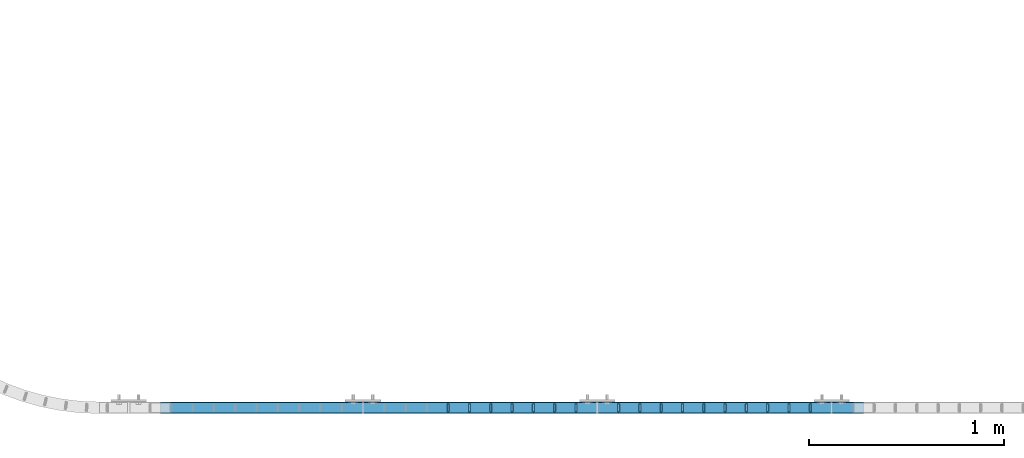
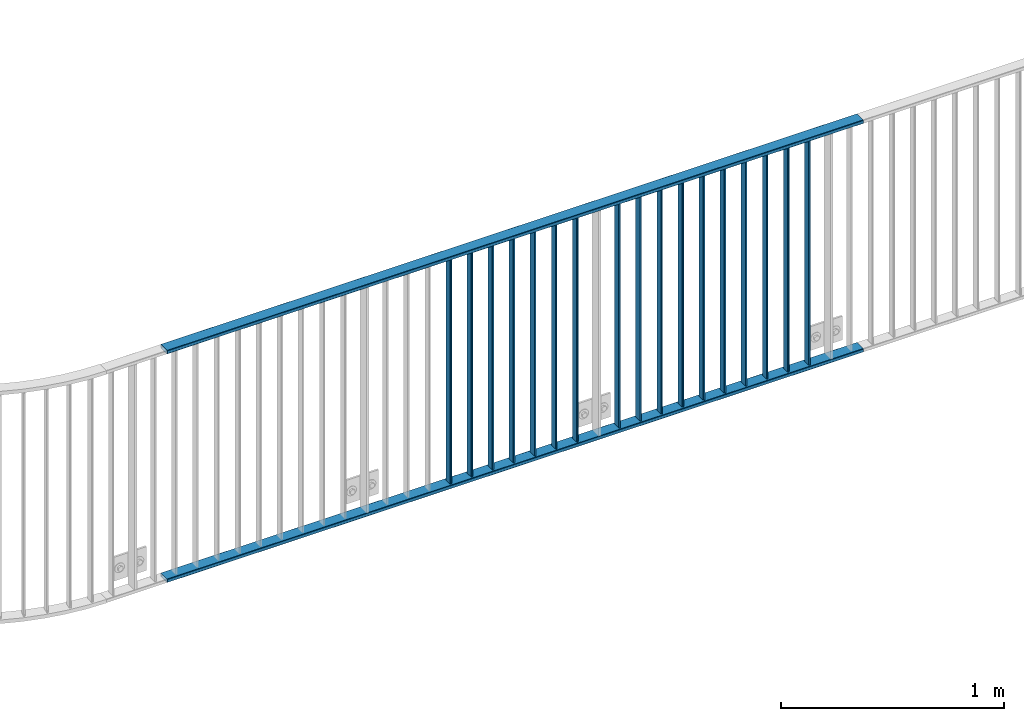
# One storey, part 19 of 156: 19 beams, 1 element without a shape of its own.
"""IFC2X3 building model written with IfcOpenShell, lengths in millimetres."""

from ifc_helpers import new_model, si_unit, frame, origin_with_axes, origin_2d_with_axis, place, context, subcontext, project, spatial, hollow_rectangle, extrude, clip, halfspace, material, type_object, element, aggregate, save


model = new_model("IFC2X3")

# Units and contexts
model_context = context("Model", 3, precision=1e-05, world=origin_with_axes())
body_context = subcontext(model_context, "Body", "Model", "MODEL_VIEW")
ifc_project = project(units=[si_unit("LENGTHUNIT", "METRE", prefix="MILLI"), si_unit("AREAUNIT", "SQUARE_METRE"), si_unit("VOLUMEUNIT", "CUBIC_METRE"), si_unit("MASSUNIT", "GRAM", prefix="KILO"), si_unit("TIMEUNIT", "SECOND"), si_unit("PLANEANGLEUNIT", "RADIAN"), si_unit("SOLIDANGLEUNIT", "STERADIAN"), si_unit("THERMODYNAMICTEMPERATUREUNIT", "DEGREE_CELSIUS"), si_unit("LUMINOUSINTENSITYUNIT", "LUMEN")], contexts=[model_context])

# Site, building, storey
site_placement = place(None, origin_with_axes())
site = spatial("IfcSite", under=ifc_project, at=site_placement, CompositionType="ELEMENT")
building_placement = place(site_placement, origin_with_axes())
building = spatial("IfcBuilding", under=site, at=building_placement, Name="Undefined", CompositionType="ELEMENT")
storey_placement = place(building_placement, origin_with_axes())
storey = spatial("IfcBuildingStorey", under=building, at=storey_placement, Name="Undefined", CompositionType="ELEMENT", Elevation=0.0)

# Assembly, beams
assembly_placement = place(storey_placement, origin_with_axes())
assembly = element("IfcElementAssembly", 1, at=assembly_placement, inside=storey, AssemblyPlace="NOTDEFINED", PredefinedType="RIGID_FRAME")
ifc_material = material(Name="STEEL/S235JR")
beam_type_1 = type_object("IfcBeamType", Name="K60/20/2", PredefinedType="NOTDEFINED")
beam_1_placement = place(assembly_placement, frame((28763.1499999997, 8480.0020904541, 2740.0), z_axis=(0.0, 1.0, 0.0), x_axis=(1.0, 0.0, 0.0)))
beam_1 = element("IfcBeam", 2, at=beam_1_placement, type_object=beam_type_1, material=ifc_material, ObjectType="K60/20/2", context=body_context, shape_type="SweptSolid", body=[
    extrude(hollow_rectangle(XDim=20.0, YDim=60.0, WallThickness=2.0, InnerFilletRadius=2.0, OuterFilletRadius=4.0, at=origin_2d_with_axis()), frame((3599.99, 0.0, 0.0), z_axis=(-1.0, 0.0, 0.0), x_axis=(0.0, -1.0, 0.0)), (0.0, 0.0, 1.0), 3599.99),
])
beam_2_placement = place(assembly_placement, frame((28763.1500000001, 8479.98209030024, 3990.0), z_axis=(0.0, 1.0, 0.0), x_axis=(1.0, 0.0, 0.0)))
beam_2 = element("IfcBeam", 3, at=beam_2_placement, type_object=beam_type_1, material=ifc_material, ObjectType="K60/20/2", context=body_context, shape_type="SweptSolid", body=[
    extrude(hollow_rectangle(XDim=20.0, YDim=60.0, WallThickness=2.0, InnerFilletRadius=2.0, OuterFilletRadius=4.0, at=origin_2d_with_axis()), frame((3599.99, 0.0, 0.0), z_axis=(-1.0, 0.0, 0.0), x_axis=(0.0, -1.0, 0.0)), (0.0, 0.0, 1.0), 3599.99),
])
beam_type_2 = type_object("IfcBeamType", Name="K40/10/1.5", PredefinedType="NOTDEFINED")
beam_3_placement = place(assembly_placement, frame((32090.899999999, 8480.00209765299, 3980.00000000003), z_axis=(0.0, 1.0, 0.0), x_axis=(0.0, 0.0, -1.0)))
beam_3 = element("IfcBeam", 4, at=beam_3_placement, type_object=beam_type_2, material=ifc_material, ObjectType="K40/10/1.5", context=body_context, shape_type="Clipping", body=[
    clip(extrude(hollow_rectangle(XDim=10.0, YDim=40.0, WallThickness=1.5, InnerFilletRadius=1.5, OuterFilletRadius=3.0, at=origin_2d_with_axis()), frame((1230.0, 0.0, 0.0), z_axis=(-1.0, 0.0, 0.0), x_axis=(0.0, -1.0, 0.0)), (0.0, 0.0, 1.0), 1230.0), halfspace(frame((-6.99999999997453, -4.34248751950508, 47.3810900558092), z_axis=(-1.0, 0.0, 0.0), x_axis=(0.0, 0.7683548141934, -0.640024124159258)), False)),
])
beam_4_placement = place(assembly_placement, frame((31981.809999999, 8480.00209765299, 3980.00000000003), z_axis=(0.0, 1.0, 0.0), x_axis=(0.0, 0.0, -1.0)))
beam_4 = element("IfcBeam", 5, at=beam_4_placement, type_object=beam_type_2, material=ifc_material, ObjectType="K40/10/1.5", context=body_context, shape_type="Clipping", body=[
    clip(extrude(hollow_rectangle(XDim=10.0, YDim=40.0, WallThickness=1.5, InnerFilletRadius=1.5, OuterFilletRadius=3.0, at=origin_2d_with_axis()), frame((1230.0, 0.0, 0.0), z_axis=(-1.0, 0.0, 0.0), x_axis=(0.0, -1.0, 0.0)), (0.0, 0.0, 1.0), 1230.0), halfspace(frame((-6.99999999997453, -4.34248751950508, 47.3810900558092), z_axis=(-1.0, 0.0, 0.0), x_axis=(0.0, 0.7683548141934, -0.640024124159258)), False)),
])
beam_5_placement = place(assembly_placement, frame((31872.719999999, 8480.00209765299, 3980.00000000003), z_axis=(0.0, 1.0, 0.0), x_axis=(0.0, 0.0, -1.0)))
beam_5 = element("IfcBeam", 6, at=beam_5_placement, type_object=beam_type_2, material=ifc_material, ObjectType="K40/10/1.5", context=body_context, shape_type="Clipping", body=[
    clip(extrude(hollow_rectangle(XDim=10.0, YDim=40.0, WallThickness=1.5, InnerFilletRadius=1.5, OuterFilletRadius=3.0, at=origin_2d_with_axis()), frame((1230.0, 0.0, 0.0), z_axis=(-1.0, 0.0, 0.0), x_axis=(0.0, -1.0, 0.0)), (0.0, 0.0, 1.0), 1230.0), halfspace(frame((-6.99999999997453, -4.34248751950508, 47.3810900558092), z_axis=(-1.0, 0.0, 0.0), x_axis=(0.0, 0.7683548141934, -0.640024124159258)), False)),
])
beam_6_placement = place(assembly_placement, frame((31763.629999999, 8480.00209765299, 3980.00000000003), z_axis=(0.0, 1.0, 0.0), x_axis=(0.0, 0.0, -1.0)))
beam_6 = element("IfcBeam", 7, at=beam_6_placement, type_object=beam_type_2, material=ifc_material, ObjectType="K40/10/1.5", context=body_context, shape_type="Clipping", body=[
    clip(extrude(hollow_rectangle(XDim=10.0, YDim=40.0, WallThickness=1.5, InnerFilletRadius=1.5, OuterFilletRadius=3.0, at=origin_2d_with_axis()), frame((1230.0, 0.0, 0.0), z_axis=(-1.0, 0.0, 0.0), x_axis=(0.0, -1.0, 0.0)), (0.0, 0.0, 1.0), 1230.0), halfspace(frame((-6.99999999997453, -4.34248751950508, 47.3810900558092), z_axis=(-1.0, 0.0, 0.0), x_axis=(0.0, 0.7683548141934, -0.640024124159258)), False)),
])
beam_7_placement = place(assembly_placement, frame((31654.539999999, 8480.00209765299, 3980.00000000003), z_axis=(0.0, 1.0, 0.0), x_axis=(0.0, 0.0, -1.0)))
beam_7 = element("IfcBeam", 8, at=beam_7_placement, type_object=beam_type_2, material=ifc_material, ObjectType="K40/10/1.5", context=body_context, shape_type="Clipping", body=[
    clip(extrude(hollow_rectangle(XDim=10.0, YDim=40.0, WallThickness=1.5, InnerFilletRadius=1.5, OuterFilletRadius=3.0, at=origin_2d_with_axis()), frame((1230.0, 0.0, 0.0), z_axis=(-1.0, 0.0, 0.0), x_axis=(0.0, -1.0, 0.0)), (0.0, 0.0, 1.0), 1230.0), halfspace(frame((-6.99999999997453, -4.34248751950508, 47.3810900558092), z_axis=(-1.0, 0.0, 0.0), x_axis=(0.0, 0.7683548141934, -0.640024124159258)), False)),
])
beam_8_placement = place(assembly_placement, frame((31545.449999999, 8480.00209765299, 3980.00000000003), z_axis=(0.0, 1.0, 0.0), x_axis=(0.0, 0.0, -1.0)))
beam_8 = element("IfcBeam", 9, at=beam_8_placement, type_object=beam_type_2, material=ifc_material, ObjectType="K40/10/1.5", context=body_context, shape_type="Clipping", body=[
    clip(extrude(hollow_rectangle(XDim=10.0, YDim=40.0, WallThickness=1.5, InnerFilletRadius=1.5, OuterFilletRadius=3.0, at=origin_2d_with_axis()), frame((1230.0, 0.0, 0.0), z_axis=(-1.0, 0.0, 0.0), x_axis=(0.0, -1.0, 0.0)), (0.0, 0.0, 1.0), 1230.0), halfspace(frame((-6.99999999997453, -4.34248751950508, 47.3810900558092), z_axis=(-1.0, 0.0, 0.0), x_axis=(0.0, 0.7683548141934, -0.640024124159258)), False)),
])
beam_9_placement = place(assembly_placement, frame((31436.359999999, 8480.00209765299, 3980.00000000003), z_axis=(0.0, 1.0, 0.0), x_axis=(0.0, 0.0, -1.0)))
beam_9 = element("IfcBeam", 10, at=beam_9_placement, type_object=beam_type_2, material=ifc_material, ObjectType="K40/10/1.5", context=body_context, shape_type="Clipping", body=[
    clip(extrude(hollow_rectangle(XDim=10.0, YDim=40.0, WallThickness=1.5, InnerFilletRadius=1.5, OuterFilletRadius=3.0, at=origin_2d_with_axis()), frame((1230.0, 0.0, 0.0), z_axis=(-1.0, 0.0, 0.0), x_axis=(0.0, -1.0, 0.0)), (0.0, 0.0, 1.0), 1230.0), halfspace(frame((-6.99999999997453, -4.34248751950508, 47.3810900558092), z_axis=(-1.0, 0.0, 0.0), x_axis=(0.0, 0.7683548141934, -0.640024124159258)), False)),
])
beam_10_placement = place(assembly_placement, frame((31327.269999999, 8480.00209765299, 3980.00000000003), z_axis=(0.0, 1.0, 0.0), x_axis=(0.0, 0.0, -1.0)))
beam_10 = element("IfcBeam", 11, at=beam_10_placement, type_object=beam_type_2, material=ifc_material, ObjectType="K40/10/1.5", context=body_context, shape_type="Clipping", body=[
    clip(extrude(hollow_rectangle(XDim=10.0, YDim=40.0, WallThickness=1.5, InnerFilletRadius=1.5, OuterFilletRadius=3.0, at=origin_2d_with_axis()), frame((1230.0, 0.0, 0.0), z_axis=(-1.0, 0.0, 0.0), x_axis=(0.0, -1.0, 0.0)), (0.0, 0.0, 1.0), 1230.0), halfspace(frame((-6.99999999997453, -4.34248751950508, 47.3810900558092), z_axis=(-1.0, 0.0, 0.0), x_axis=(0.0, 0.7683548141934, -0.640024124159258)), False)),
])
beam_11_placement = place(assembly_placement, frame((31218.179999999, 8480.00209765299, 3980.00000000003), z_axis=(0.0, 1.0, 0.0), x_axis=(0.0, 0.0, -1.0)))
beam_11 = element("IfcBeam", 12, at=beam_11_placement, type_object=beam_type_2, material=ifc_material, ObjectType="K40/10/1.5", context=body_context, shape_type="Clipping", body=[
    clip(extrude(hollow_rectangle(XDim=10.0, YDim=40.0, WallThickness=1.5, InnerFilletRadius=1.5, OuterFilletRadius=3.0, at=origin_2d_with_axis()), frame((1230.0, 0.0, 0.0), z_axis=(-1.0, 0.0, 0.0), x_axis=(0.0, -1.0, 0.0)), (0.0, 0.0, 1.0), 1230.0), halfspace(frame((-6.99999999997453, -4.34248751950508, 47.3810900558092), z_axis=(-1.0, 0.0, 0.0), x_axis=(0.0, 0.7683548141934, -0.640024124159258)), False)),
])
beam_12_placement = place(assembly_placement, frame((31109.089999999, 8480.00209765299, 3980.00000000003), z_axis=(0.0, 1.0, 0.0), x_axis=(0.0, 0.0, -1.0)))
beam_12 = element("IfcBeam", 13, at=beam_12_placement, type_object=beam_type_2, material=ifc_material, ObjectType="K40/10/1.5", context=body_context, shape_type="Clipping", body=[
    clip(extrude(hollow_rectangle(XDim=10.0, YDim=40.0, WallThickness=1.5, InnerFilletRadius=1.5, OuterFilletRadius=3.0, at=origin_2d_with_axis()), frame((1230.0, 0.0, 0.0), z_axis=(-1.0, 0.0, 0.0), x_axis=(0.0, -1.0, 0.0)), (0.0, 0.0, 1.0), 1230.0), halfspace(frame((-6.99999999997453, -4.34248751950508, 47.3810900558092), z_axis=(-1.0, 0.0, 0.0), x_axis=(0.0, 0.7683548141934, -0.640024124159258)), False)),
])
beam_13_placement = place(assembly_placement, frame((30890.899999999, 8480.00209765299, 3980.00000000003), z_axis=(0.0, 1.0, 0.0), x_axis=(0.0, 0.0, -1.0)))
beam_13 = element("IfcBeam", 14, at=beam_13_placement, type_object=beam_type_2, material=ifc_material, ObjectType="K40/10/1.5", context=body_context, shape_type="Clipping", body=[
    clip(extrude(hollow_rectangle(XDim=10.0, YDim=40.0, WallThickness=1.5, InnerFilletRadius=1.5, OuterFilletRadius=3.0, at=origin_2d_with_axis()), frame((1230.0, 0.0, 0.0), z_axis=(-1.0, 0.0, 0.0), x_axis=(0.0, -1.0, 0.0)), (0.0, 0.0, 1.0), 1230.0), halfspace(frame((-6.99999999997453, -4.34248751950508, 47.3810900558092), z_axis=(-1.0, 0.0, 0.0), x_axis=(0.0, 0.7683548141934, -0.640024124159258)), False)),
])
beam_14_placement = place(assembly_placement, frame((30781.809999999, 8480.00209765299, 3980.00000000003), z_axis=(0.0, 1.0, 0.0), x_axis=(0.0, 0.0, -1.0)))
beam_14 = element("IfcBeam", 15, at=beam_14_placement, type_object=beam_type_2, material=ifc_material, ObjectType="K40/10/1.5", context=body_context, shape_type="Clipping", body=[
    clip(extrude(hollow_rectangle(XDim=10.0, YDim=40.0, WallThickness=1.5, InnerFilletRadius=1.5, OuterFilletRadius=3.0, at=origin_2d_with_axis()), frame((1230.0, 0.0, 0.0), z_axis=(-1.0, 0.0, 0.0), x_axis=(0.0, -1.0, 0.0)), (0.0, 0.0, 1.0), 1230.0), halfspace(frame((-6.99999999997453, -4.34248751950508, 47.3810900558092), z_axis=(-1.0, 0.0, 0.0), x_axis=(0.0, 0.7683548141934, -0.640024124159258)), False)),
])
beam_15_placement = place(assembly_placement, frame((30672.719999999, 8480.00209765299, 3980.00000000003), z_axis=(0.0, 1.0, 0.0), x_axis=(0.0, 0.0, -1.0)))
beam_15 = element("IfcBeam", 16, at=beam_15_placement, type_object=beam_type_2, material=ifc_material, ObjectType="K40/10/1.5", context=body_context, shape_type="Clipping", body=[
    clip(extrude(hollow_rectangle(XDim=10.0, YDim=40.0, WallThickness=1.5, InnerFilletRadius=1.5, OuterFilletRadius=3.0, at=origin_2d_with_axis()), frame((1230.0, 0.0, 0.0), z_axis=(-1.0, 0.0, 0.0), x_axis=(0.0, -1.0, 0.0)), (0.0, 0.0, 1.0), 1230.0), halfspace(frame((-6.99999999997453, -4.34248751950508, 47.3810900558092), z_axis=(-1.0, 0.0, 0.0), x_axis=(0.0, 0.7683548141934, -0.640024124159258)), False)),
])
beam_16_placement = place(assembly_placement, frame((30563.629999999, 8480.00209765299, 3980.00000000003), z_axis=(0.0, 1.0, 0.0), x_axis=(0.0, 0.0, -1.0)))
beam_16 = element("IfcBeam", 17, at=beam_16_placement, type_object=beam_type_2, material=ifc_material, ObjectType="K40/10/1.5", context=body_context, shape_type="Clipping", body=[
    clip(extrude(hollow_rectangle(XDim=10.0, YDim=40.0, WallThickness=1.5, InnerFilletRadius=1.5, OuterFilletRadius=3.0, at=origin_2d_with_axis()), frame((1230.0, 0.0, 0.0), z_axis=(-1.0, 0.0, 0.0), x_axis=(0.0, -1.0, 0.0)), (0.0, 0.0, 1.0), 1230.0), halfspace(frame((-6.99999999997453, -4.34248751950508, 47.3810900558092), z_axis=(-1.0, 0.0, 0.0), x_axis=(0.0, 0.7683548141934, -0.640024124159258)), False)),
])
beam_17_placement = place(assembly_placement, frame((30454.539999999, 8480.00209765299, 3980.00000000003), z_axis=(0.0, 1.0, 0.0), x_axis=(0.0, 0.0, -1.0)))
beam_17 = element("IfcBeam", 18, at=beam_17_placement, type_object=beam_type_2, material=ifc_material, ObjectType="K40/10/1.5", context=body_context, shape_type="Clipping", body=[
    clip(extrude(hollow_rectangle(XDim=10.0, YDim=40.0, WallThickness=1.5, InnerFilletRadius=1.5, OuterFilletRadius=3.0, at=origin_2d_with_axis()), frame((1230.0, 0.0, 0.0), z_axis=(-1.0, 0.0, 0.0), x_axis=(0.0, -1.0, 0.0)), (0.0, 0.0, 1.0), 1230.0), halfspace(frame((-6.99999999997453, -4.34248751950508, 47.3810900558092), z_axis=(-1.0, 0.0, 0.0), x_axis=(0.0, 0.7683548141934, -0.640024124159258)), False)),
])
beam_18_placement = place(assembly_placement, frame((30345.449999999, 8480.00209765299, 3980.00000000003), z_axis=(0.0, 1.0, 0.0), x_axis=(0.0, 0.0, -1.0)))
beam_18 = element("IfcBeam", 19, at=beam_18_placement, type_object=beam_type_2, material=ifc_material, ObjectType="K40/10/1.5", context=body_context, shape_type="Clipping", body=[
    clip(extrude(hollow_rectangle(XDim=10.0, YDim=40.0, WallThickness=1.5, InnerFilletRadius=1.5, OuterFilletRadius=3.0, at=origin_2d_with_axis()), frame((1230.0, 0.0, 0.0), z_axis=(-1.0, 0.0, 0.0), x_axis=(0.0, -1.0, 0.0)), (0.0, 0.0, 1.0), 1230.0), halfspace(frame((-6.99999999997453, -4.34248751950508, 47.3810900558092), z_axis=(-1.0, 0.0, 0.0), x_axis=(0.0, 0.7683548141934, -0.640024124159258)), False)),
])
beam_19_placement = place(assembly_placement, frame((30236.359999999, 8480.00209765299, 3980.00000000003), z_axis=(0.0, 1.0, 0.0), x_axis=(0.0, 0.0, -1.0)))
beam_19 = element("IfcBeam", 20, at=beam_19_placement, type_object=beam_type_2, material=ifc_material, ObjectType="K40/10/1.5", context=body_context, shape_type="Clipping", body=[
    clip(extrude(hollow_rectangle(XDim=10.0, YDim=40.0, WallThickness=1.5, InnerFilletRadius=1.5, OuterFilletRadius=3.0, at=origin_2d_with_axis()), frame((1230.0, 0.0, 0.0), z_axis=(-1.0, 0.0, 0.0), x_axis=(0.0, -1.0, 0.0)), (0.0, 0.0, 1.0), 1230.0), halfspace(frame((-6.99999999997453, -4.34248751950508, 47.3810900558092), z_axis=(-1.0, 0.0, 0.0), x_axis=(0.0, 0.7683548141934, -0.640024124159258)), False)),
])
aggregate(assembly, [beam_1, beam_2, beam_3, beam_4, beam_5, beam_6, beam_7, beam_8, beam_9, beam_10, beam_11, beam_12, beam_13, beam_14, beam_15, beam_16, beam_17, beam_18, beam_19])

save(model, "model.ifc")
